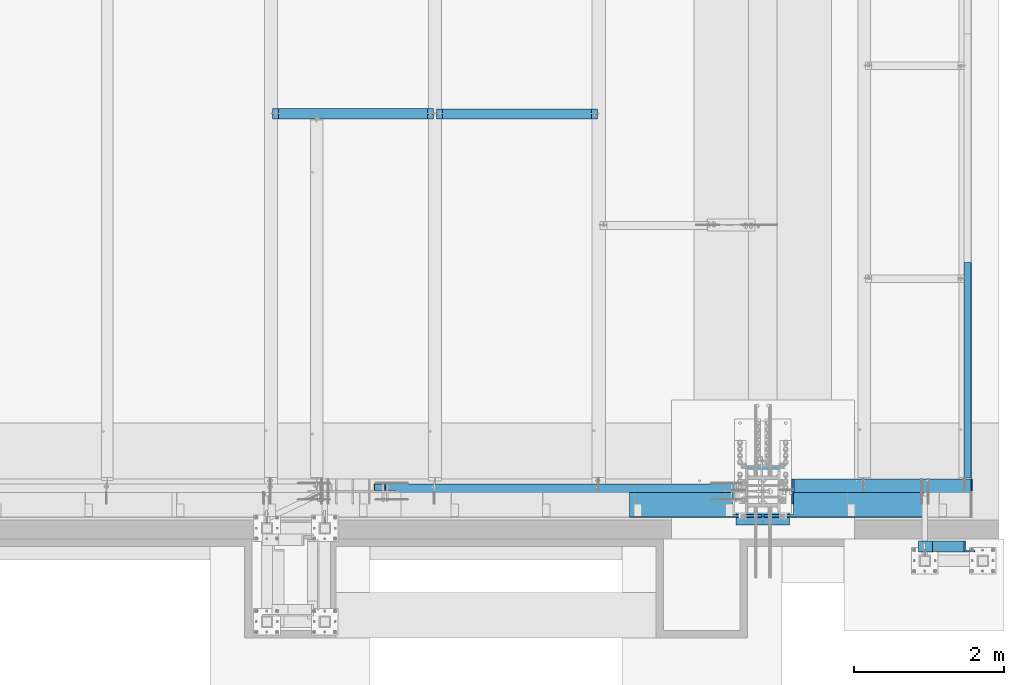
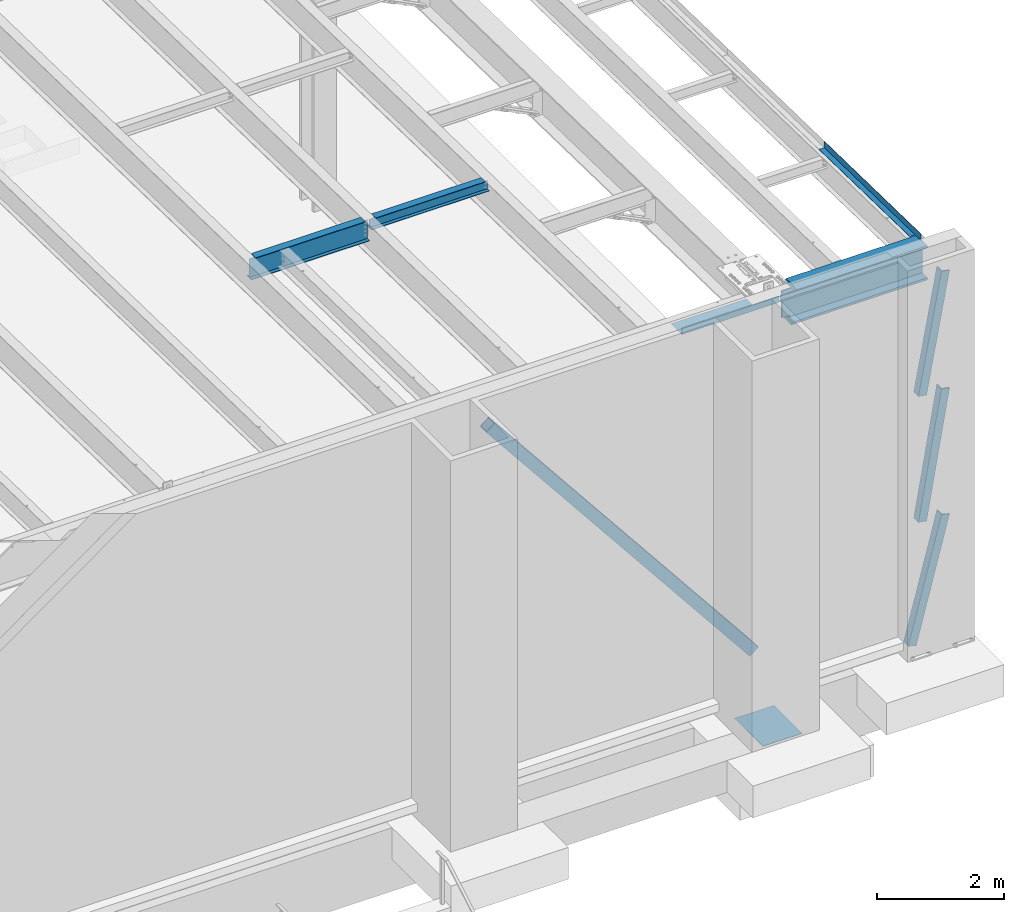
# One storey, part 1111 of 1763: 7 beams, 4 members, 8 elements without a shape of their own.
"""IFC2X3 building model written with IfcOpenShell, lengths in millimetres."""

from ifc_helpers import new_model, si_unit, frame, origin_with_axes, place, context, subcontext, project, spatial, faceted_brep, material, type_object, element, aggregate, save


model = new_model("IFC2X3")

# Units and contexts
model_context = context("Model", 3, precision=1e-05, world=origin_with_axes())
body_context = subcontext(model_context, "Body", "Model", "MODEL_VIEW")
ifc_project = project(units=[si_unit("LENGTHUNIT", "METRE", prefix="MILLI"), si_unit("AREAUNIT", "SQUARE_METRE"), si_unit("VOLUMEUNIT", "CUBIC_METRE"), si_unit("MASSUNIT", "GRAM", prefix="KILO"), si_unit("TIMEUNIT", "SECOND"), si_unit("PLANEANGLEUNIT", "RADIAN"), si_unit("SOLIDANGLEUNIT", "STERADIAN"), si_unit("THERMODYNAMICTEMPERATUREUNIT", "DEGREE_CELSIUS"), si_unit("LUMINOUSINTENSITYUNIT", "LUMEN")], contexts=[model_context])

# Site, building, storey
site_placement = place(None, origin_with_axes())
site = spatial("IfcSite", under=ifc_project, at=site_placement, CompositionType="ELEMENT")
building_placement = place(site_placement, origin_with_axes())
building = spatial("IfcBuilding", under=site, at=building_placement, Name="Undefined", CompositionType="ELEMENT")
storey_placement = place(building_placement, origin_with_axes())
storey = spatial("IfcBuildingStorey", under=building, at=storey_placement, Name="Undefined", CompositionType="ELEMENT", Elevation=0.0)

# Assembly, beam
assembly_1_placement = place(storey_placement, origin_with_axes())
assembly_1 = element("IfcElementAssembly", 1, at=assembly_1_placement, inside=storey, Name="BEAM", AssemblyPlace="NOTDEFINED", PredefinedType="RIGID_FRAME")
ifc_material_1 = material(Name="STEEL/A992")
beam_type_1 = type_object("IfcBeamType", Name="W8X18", PredefinedType="NOTDEFINED")
beam_1_placement = place(assembly_1_placement, frame((-28396.6372736983, -8686.8, 11996.3724330607), z_axis=(0.0, 0.0, 1.0), x_axis=(1.0, 0.0, 0.0)))
beam_1 = element("IfcBeam", 2, at=beam_1_placement, type_object=beam_type_1, material=ifc_material_1, Name="BEAM", ObjectType="W8X18", context=body_context, shape_type="Brep", body=[
    faceted_brep([(2084.38749999999, -66.6749999999993, 103.1875), (2084.38749999999, -66.6749999999993, 95.25), (2084.38749999999, -3.17499999999927, 95.25), (2084.38749999999, -3.17499999999927, 77.5275014878825), (2084.38749999999, 3.17499999999927, 77.5275014878825), (2084.38749999999, 3.17499999999927, 95.25), (2084.38749999999, 66.6749999999993, 95.25), (2084.38749999999, 66.6749999999993, 103.1875), (2085.35422992258, -3.17499999999927, 72.6674219698361), (2085.35422992258, 3.17499999999927, 72.6674219698361), (2088.10724382306, -3.17500000000018, 68.5472454972532), (2088.10724382306, 3.17500000000018, 68.5472454972532), (2092.22742029121, -3.17500000000018, 65.7942315967757), (2092.22742029121, 3.17500000000018, 65.7942315967757), (2097.08749980926, -3.17500000000018, 64.8275016741882), (2097.08749980926, 3.17500000000018, 64.8275016741882), (2166.93749999999, -3.17500000000018, 64.8275016741882), (2166.93749999999, 3.17500000000018, 64.8275016741882), (100.012500000001, -66.6749999999993, 103.1875), (100.012500000001, 66.6749999999993, 103.1875), (100.012500000001, 66.6749999999993, 95.25), (100.012500000001, 3.17499999999927, 95.25), (100.012500000001, 3.17499999999927, 77.5275014878825), (100.012500000001, -3.17499999999927, 77.5275014878825), (100.012500000001, -3.17499999999927, 95.25), (100.012500000001, -66.6749999999993, 95.25), (99.0457700774132, 3.17499999999927, 72.6674219698361), (99.0457700774132, -3.17499999999927, 72.6674219698361), (96.2927561769247, 3.17500000000018, 68.5472454911378), (96.2927561769247, -3.17500000000018, 68.5472454911378), (92.1725797087711, 3.17500000000018, 65.7942315906603), (92.1725797087711, -3.17500000000018, 65.7942315906603), (87.3125001907247, 3.17500000000018, 64.8275016680727), (87.3125001907247, -3.17500000000018, 64.8275016680727), (17.4624999999905, 3.17500000000018, 64.8275016680727), (17.4624999999905, -3.17500000000018, 64.8275016680727), (17.4624999999905, 3.17500000000018, -95.25), (17.4624999999905, 66.6750000000002, -95.25), (17.4624999999905, 66.6750000000002, -103.1875), (17.4624999999905, -66.6750000000002, -103.1875), (17.4624999999905, -66.6750000000002, -95.25), (17.4624999999905, -3.17500000000018, -95.25), (2166.93749999999, 3.17500000000018, -95.25), (2166.93749999999, 66.6750000000002, -95.25), (2166.93749999999, 66.6750000000002, -103.1875), (2166.93749999999, -66.6750000000002, -103.1875), (2166.93749999999, -66.6750000000002, -95.25), (2166.93749999999, -3.17500000000018, -95.25)], [[[0, 1, 2, 3, 4, 5, 6, 7]], [[8, 9, 4, 3]], [[10, 11, 9, 8]], [[12, 13, 11, 10]], [[14, 15, 13, 12]], [[16, 17, 15, 14]], [[18, 19, 20, 21, 22, 23, 24, 25]], [[23, 22, 26, 27]], [[27, 26, 28, 29]], [[29, 28, 30, 31]], [[31, 30, 32, 33]], [[33, 32, 34, 35]], [[36, 37, 38, 39, 40, 41, 35, 34]], [[37, 36, 42, 43]], [[38, 37, 43, 44]], [[39, 38, 44, 45]], [[40, 39, 45, 46]], [[41, 40, 46, 47]], [[12, 10, 8, 3, 2, 24, 23, 27, 29, 31, 33, 35, 41, 47, 16, 14]], [[25, 24, 2, 1]], [[18, 25, 1, 0]], [[19, 18, 0, 7]], [[20, 19, 7, 6]], [[21, 20, 6, 5]], [[42, 36, 34, 32, 30, 28, 26, 22, 21, 5, 4, 9, 11, 13, 15, 17]], [[47, 46, 45, 44, 43, 42, 17, 16]]]),
])
aggregate(assembly_1, [beam_1])

# Assembly, members
assembly_2_placement = place(storey_placement, origin_with_axes())
assembly_2 = element("IfcElementAssembly", 3, at=assembly_2_placement, inside=storey, Name="FRAME", AssemblyPlace="NOTDEFINED", PredefinedType="RIGID_FRAME")
ifc_material_2 = material(Name="STEEL/A36")
member_type_1 = type_object("IfcMemberType", Name="L6X6X7/8", PredefinedType="NOTDEFINED")
member_1_placement = place(assembly_2_placement, frame((-21894.238056465, -14450.1432982799, 5067.3), z_axis=(0.967568844116864, 0.0, -0.252607466030511), x_axis=(0.252607466030511, 0.0, 0.967568844116864)))
member_1 = element("IfcMember", 4, at=member_1_placement, type_object=member_type_1, material=ifc_material_2, Name="V. BRACE", ObjectType="L6X6X7/8", context=body_context, shape_type="Brep", body=[
    faceted_brep([(60.0245163736663, 76.2000000000007, -76.1999999999643), (59.3416290607647, 76.2000000000007, 76.2000000000189), (2461.06518876234, 76.2000000000007, 76.2000000010594), (2461.0651887624, 76.2000000000007, -76.1999999989166), (59.3416290607647, 53.9750000000004, 76.2000000000189), (2461.06518876234, 53.9750000000004, 76.2000000010594), (59.9249286405347, 53.9750000000004, -53.9749999999658), (2461.06518876239, 53.9750000000004, -53.9749999989217), (59.9249286405347, -76.2000000000007, -53.9749999999658), (2461.06518876239, -76.2000000000007, -53.9749999989217), (60.0245163736663, -76.2000000000007, -76.1999999999643), (2461.0651887624, -76.2000000000007, -76.1999999989166)], [[[0, 1, 2, 3]], [[1, 4, 5, 2]], [[4, 6, 7, 5]], [[6, 8, 9, 7]], [[8, 10, 11, 9]], [[10, 0, 3, 11]], [[5, 7, 9, 11, 3, 2]], [[10, 8, 6, 4, 1, 0]]]),
])
member_2_placement = place(assembly_2_placement, frame((-21692.7923567803, -14450.1432982799, 9867.9), z_axis=(0.983225526923755, 0.0, -0.182393977985856), x_axis=(0.182393977985856, 0.0, 0.983225526923755)))
member_2 = element("IfcMember", 5, at=member_2_placement, type_object=member_type_1, material=ifc_material_2, Name="V. BRACE", ObjectType="L6X6X7/8", context=body_context, shape_type="Brep", body=[
    faceted_brep([(9.09494701772928e-13, 76.2000000000007, -76.2000000000844), (0.0, 76.2000000000007, 76.2000000000771), (2299.16732010794, 76.2000000000007, 76.2000000008775), (2299.16732010795, 76.2000000000007, -76.199999999284), (0.0, 53.9750000000004, 76.2000000000771), (2299.16732010794, 53.9750000000004, 76.2000000008775), (1.81898940354586e-12, 53.9750000000004, -53.9750000000604), (2299.16732010795, 53.9750000000004, -53.97499999926), (1.81898940354586e-12, -76.2000000000007, -53.9750000000604), (2299.16732010795, -76.2000000000007, -53.97499999926), (9.09494701772928e-13, -76.2000000000007, -76.2000000000844), (2299.16732010795, -76.2000000000007, -76.199999999284)], [[[0, 1, 2, 3]], [[1, 4, 5, 2]], [[4, 6, 7, 5]], [[6, 8, 9, 7]], [[8, 10, 11, 9]], [[10, 0, 3, 11]], [[5, 7, 9, 11, 3, 2]], [[10, 8, 6, 4, 1, 0]]]),
])
member_3_placement = place(assembly_2_placement, frame((-21692.5763856551, -14450.1432982799, 7448.55), z_axis=(0.985337026870794, 0.0, -0.170619293977627), x_axis=(0.170619293977628, 0.0, 0.985337026870794)))
member_3 = element("IfcMember", 6, at=member_3_placement, type_object=member_type_1, material=ifc_material_2, Name="V. BRACE", ObjectType="L6X6X7/8", context=body_context, shape_type="Brep", body=[
    faceted_brep([(9.09494701772928e-13, 76.2000000000007, -76.2000000000844), (0.0, 76.2000000000007, 76.2000000000771), (2455.35277151341, 76.2000000000007, 76.2000000014268), (2455.35277151334, 76.2000000000007, -76.199999998742), (0.0, 53.9750000000004, 76.2000000000771), (2455.35277151341, 53.9750000000004, 76.2000000014268), (1.81898940354586e-12, 53.9750000000004, -53.9750000000604), (2455.35277151335, 53.9750000000004, -53.974999998718), (1.81898940354586e-12, -76.2000000000007, -53.9750000000604), (2455.35277151335, -76.2000000000007, -53.974999998718), (9.09494701772928e-13, -76.2000000000007, -76.2000000000844), (2455.35277151334, -76.2000000000007, -76.199999998742)], [[[0, 1, 2, 3]], [[1, 4, 5, 2]], [[4, 6, 7, 5]], [[6, 8, 9, 7]], [[8, 10, 11, 9]], [[10, 0, 3, 11]], [[5, 7, 9, 11, 3, 2]], [[10, 8, 6, 4, 1, 0]]]),
])
aggregate(assembly_2, [member_1, member_2, member_3])

# Assembly, beam
assembly_3_placement = place(storey_placement, origin_with_axes())
assembly_3 = element("IfcElementAssembly", 7, at=assembly_3_placement, inside=storey, Name="BEAM", AssemblyPlace="NOTDEFINED", PredefinedType="RIGID_FRAME")
beam_type_2 = type_object("IfcBeamType", PredefinedType="NOTDEFINED")
beam_2_placement = place(assembly_3_placement, frame((-21348.1372736984, -12191.7219162731, 12176.0092546754), z_axis=(0.0, -0.999781542838788, 0.0209013539966307), x_axis=(1.0, 0.0, 0.0)))
beam_2 = element("IfcBeam", 8, at=beam_2_placement, type_object=beam_type_2, material=ifc_material_2, Name="BENT_PLATE", context=body_context, shape_type="Brep", body=[
    faceted_brep([(101.59999847411, -3.17499999956453, 1342.05830135889), (101.59999847411, 3.17500019330328, 1342.05830135255), (95.2499984741116, 3.17500000044129, 1342.05830135255), (0.0, 3.17500000044492, 1342.05830135255), (0.0, -3.17499999955908, 1342.05830135889), (101.599999809252, 3.17499999999927, 1524.0), (95.2499984741262, 3.17499999910251, 1523.99999999978), (101.599998474125, -3.17499999909887, -1523.99999999978), (0.0, -3.17499999999927, -1523.99999999999), (0.0, 3.17499999999927, -1523.99999999999), (95.2499984741262, 3.17500000090149, -1523.99999999977), (95.2499984741262, 123.825003589236, -1523.9999999997), (101.599998474125, 123.825003589236, -1523.9999999997), (101.599998474125, 123.825003587437, 1523.99999999985), (95.2499984741262, 123.825003587437, 1523.99999999985)], [[[0, 1, 2, 3, 4]], [[5, 6, 2, 1]], [[7, 8, 9, 10, 11, 12]], [[13, 12, 11, 14]], [[0, 7, 12, 13, 5, 1]], [[8, 7, 0, 4]], [[9, 8, 4, 3]], [[10, 9, 3, 2]], [[14, 11, 10, 2, 6]], [[13, 14, 6, 5]]]),
])
aggregate(assembly_3, [beam_2])

assembly_4_placement = place(storey_placement, origin_with_axes())
assembly_4 = element("IfcElementAssembly", 9, at=assembly_4_placement, inside=storey, Name="BEAM", AssemblyPlace="NOTDEFINED", PredefinedType="RIGID_FRAME")
beam_type_3 = type_object("IfcBeamType", Name="W16X26", PredefinedType="NOTDEFINED")
beam_3_placement = place(assembly_4_placement, frame((-30581.0372736983, -8686.8, 11899.5349330607), z_axis=(0.0, 0.0, 1.0), x_axis=(1.0, 0.0, 0.0)))
beam_3 = element("IfcBeam", 10, at=beam_3_placement, type_object=beam_type_3, material=ifc_material_1, Name="BEAM", ObjectType="W16X26", context=body_context, shape_type="Brep", body=[
    faceted_brep([(2084.38749999999, -69.8500000000004, 200.025), (2084.38749999999, -69.8500000000004, 190.5), (2084.38749999999, -3.17499999999927, 190.5), (2084.38749999999, -3.17499999999927, 180.715001487652), (2084.38749999999, 3.17499999999927, 180.715001487652), (2084.38749999999, 3.17499999999927, 190.5), (2084.38749999999, 69.8500000000004, 190.5), (2084.38749999999, 69.8500000000004, 200.025), (2085.35422992258, -3.17499999999927, 175.854921969605), (2085.35422992258, 3.17499999999927, 175.854921969605), (2088.10724382306, -3.17499999999927, 171.734745501451), (2088.10724382306, 3.17499999999927, 171.734745501451), (2092.22742029121, -3.17499999999927, 168.981731600974), (2092.22742029121, 3.17499999999927, 168.981731600974), (2097.08749980926, -3.17499999999927, 168.015001678386), (2097.08749980926, 3.17499999999927, 168.015001678386), (2166.93749999999, -3.17499999999927, 168.015001678386), (2166.93749999999, 3.17499999999927, 168.015001678386), (100.012500000012, -69.8500000000004, 200.025), (100.012500000012, 69.8500000000004, 200.025), (100.012500000012, 69.8500000000004, 190.5), (100.012500000012, 3.17499999999927, 190.5), (100.012500000012, 3.17499999999927, 180.715001488035), (100.012500000012, -3.17499999999927, 180.715001488035), (100.012500000012, -3.17499999999927, 190.5), (100.012500000012, -69.8500000000004, 190.5), (99.0457700774205, 3.17499999999927, 175.854921969989), (99.0457700774205, -3.17499999999927, 175.854921969989), (96.2927561769466, 3.17499999999927, 171.734745501835), (96.2927561769466, -3.17499999999927, 171.734745501835), (92.1725797087929, 3.17499999999927, 168.981731601358), (92.1725797087929, -3.17499999999927, 168.981731601358), (87.3125001907465, 3.17499999999927, 168.01500167877), (87.3125001907465, -3.17499999999927, 168.01500167877), (17.4625000000087, 3.17499999999927, 168.01500167877), (17.4625000000087, -3.17499999999927, 168.01500167877), (17.4625000000087, 3.17499999999927, -190.5), (17.4625000000087, 69.8500000000004, -190.5), (17.4625000000087, 69.8500000000004, -200.025), (17.4625000000087, -69.8500000000004, -200.025), (17.4625000000087, -69.8500000000004, -190.5), (17.4625000000087, -3.17499999999927, -190.5), (2166.93749999999, 3.17499999999927, -190.5), (2166.93749999999, 69.8500000000004, -190.5), (2166.93749999999, 69.8500000000004, -200.025), (2166.93749999999, -69.8500000000004, -200.025), (2166.93749999999, -69.8500000000004, -190.5), (2166.93749999999, -3.17499999999927, -190.5)], [[[0, 1, 2, 3, 4, 5, 6, 7]], [[8, 9, 4, 3]], [[10, 11, 9, 8]], [[12, 13, 11, 10]], [[14, 15, 13, 12]], [[16, 17, 15, 14]], [[18, 19, 20, 21, 22, 23, 24, 25]], [[23, 22, 26, 27]], [[27, 26, 28, 29]], [[29, 28, 30, 31]], [[31, 30, 32, 33]], [[33, 32, 34, 35]], [[36, 37, 38, 39, 40, 41, 35, 34]], [[37, 36, 42, 43]], [[38, 37, 43, 44]], [[39, 38, 44, 45]], [[40, 39, 45, 46]], [[41, 40, 46, 47]], [[12, 10, 8, 3, 2, 24, 23, 27, 29, 31, 33, 35, 41, 47, 16, 14]], [[25, 24, 2, 1]], [[18, 25, 1, 0]], [[19, 18, 0, 7]], [[20, 19, 7, 6]], [[21, 20, 6, 5]], [[42, 36, 34, 32, 30, 28, 26, 22, 21, 5, 4, 9, 11, 13, 15, 17]], [[47, 46, 45, 44, 43, 42, 17, 16]]]),
])
aggregate(assembly_4, [beam_3])

assembly_5_placement = place(storey_placement, origin_with_axes())
assembly_5 = element("IfcElementAssembly", 11, at=assembly_5_placement, inside=storey, Name="BEAM", AssemblyPlace="NOTDEFINED", PredefinedType="RIGID_FRAME")
beam_type_4 = type_object("IfcBeamType", PredefinedType="NOTDEFINED")
beam_4_placement = place(assembly_5_placement, frame((-22948.3372730615, -13728.6998186171, 12207.875), z_axis=(-1.0, 0.0, 0.0), x_axis=(0.0, -1.0, 0.0)))
beam_4 = element("IfcBeam", 12, at=beam_4_placement, type_object=beam_type_4, material=ifc_material_2, Name="BENT_PLATE", context=body_context, shape_type="Brep", body=[
    faceted_brep([(292.099990341079, -3.17499999999927, 673.100030919406), (292.099990341079, 3.17499999999927, 673.100030919406), (0.0, 3.17500000000291, 673.099987030029), (0.0, -3.17500000000291, 673.099987030029), (292.099987518222, -3.17499999999927, 1066.8), (292.099987518222, 3.17499999999927, 1066.8), (336.549987792969, -3.17499999999927, -1066.8), (0.0, -3.17499999999927, -1066.8), (0.0, 3.17499999999927, -1066.8), (330.19998779297, 3.17499999999927, -1066.8), (330.19998779297, 123.825000000001, -1066.8), (336.549987792969, 123.825000000001, -1066.8), (330.19998779297, 3.17499999999927, 1066.8), (330.19998779297, 123.825000000001, 1066.8), (336.549987792969, 123.825000000001, 1066.8), (336.549987792969, -3.17499999999927, 1066.8)], [[[0, 1, 2, 3]], [[4, 5, 1, 0]], [[6, 7, 8, 9, 10, 11]], [[9, 12, 13, 10]], [[14, 11, 10, 13]], [[15, 6, 11, 14]], [[3, 7, 6, 15, 4, 0]], [[8, 7, 3, 2]], [[12, 9, 8, 2, 1, 5]], [[15, 14, 13, 12, 5, 4]]]),
])

assembly_6_placement = place(storey_placement, origin_with_axes())
assembly_6 = element("IfcElementAssembly", 13, at=assembly_6_placement, inside=storey, Name="BEAM", AssemblyPlace="NOTDEFINED", PredefinedType="RIGID_FRAME")
beam_5_placement = place(assembly_6_placement, frame((-24921.5997736984, -13728.6998186171, 12207.875), z_axis=(-1.0, 0.0, 0.0), x_axis=(0.0, -1.0, 0.0)))
beam_5 = element("IfcBeam", 14, at=beam_5_placement, type_object=beam_type_4, material=ifc_material_2, Name="BENT_PLATE", context=body_context, shape_type="Brep", body=[
    faceted_brep([(292.099992404377, -3.17499999999927, -487.362530517577), (292.099992404377, 3.17499999999927, -487.362530517577), (292.099987829859, 3.17499999999927, -881.0625), (292.099987829859, -3.17499999999927, -881.0625), (0.0, -3.17499999999927, -487.362530517577), (0.0, 3.17499999999927, -487.362530517577), (330.19998779297, 3.17499999999927, 881.0625), (0.0, 3.17499999999927, 881.0625), (0.0, -3.17499999999927, 881.0625), (336.549987792969, -3.17499999999927, 881.0625), (336.549987792969, 123.825000000001, 881.0625), (330.19998779297, 123.825000000001, 881.0625), (330.19998779297, 3.17499999999927, -881.0625), (330.19998779297, 123.825000000001, -881.0625), (336.549987792969, 123.825000000001, -881.0625), (336.549987792969, -3.17499999999927, -881.0625)], [[[0, 1, 2, 3]], [[4, 5, 1, 0]], [[6, 7, 8, 9, 10, 11]], [[12, 6, 11, 13]], [[10, 14, 13, 11]], [[9, 15, 14, 10]], [[12, 13, 14, 15, 3, 2]], [[7, 6, 12, 2, 1, 5]], [[8, 7, 5, 4]], [[15, 9, 8, 4, 0, 3]]]),
])
aggregate(assembly_6, [beam_5])

assembly_7_placement = place(storey_placement, origin_with_axes())
assembly_7 = element("IfcElementAssembly", 15, at=assembly_7_placement, inside=storey, Name="TEMPLATE", AssemblyPlace="NOTDEFINED", PredefinedType="RIGID_FRAME")
beam_type_5 = type_object("IfcBeamType", PredefinedType="NOTDEFINED")
beam_6_placement = place(assembly_7_placement, frame((-24027.8372736984, -14160.5000000001, 3851.275), z_axis=(-1.0, 0.0, 0.0), x_axis=(0.0, 1.0, 0.0)))
beam_6 = element("IfcBeam", 16, at=beam_6_placement, type_object=beam_type_5, material=ifc_material_2, Name="TEMPLATE", context=body_context, shape_type="Brep", body=[
    faceted_brep([(0.0, 3.17500000000018, -355.599999999999), (0.0, 3.17500000000018, 355.599999999999), (889.0, 3.17500000000018, 355.599999999999), (889.0, 3.17500000000018, -355.599999999999), (0.0, -3.17500000000018, 355.599999999999), (889.0, -3.17500000000018, 355.599999999999), (0.0, -3.17500000000018, -355.599999999999), (889.0, -3.17500000000018, -355.599999999999)], [[[0, 1, 2, 3]], [[1, 4, 5, 2]], [[4, 6, 7, 5]], [[6, 0, 3, 7]], [[5, 7, 3, 2]], [[6, 4, 1, 0]]]),
])
aggregate(assembly_7, [beam_6])

# Assembly, member
assembly_8_placement = place(storey_placement, origin_with_axes())
assembly_8 = element("IfcElementAssembly", 17, at=assembly_8_placement, inside=storey, Name="V. BRACE", AssemblyPlace="NOTDEFINED", PredefinedType="RIGID_FRAME")
ifc_material_3 = material()
member_type_2 = type_object("IfcMemberType", Name="HSS8X8X1/2", PredefinedType="NOTDEFINED")
member_4_placement = place(assembly_8_placement, frame((-24027.8372736984, -13716.0, 5054.6), z_axis=(0.780585099299328, 0.0, 0.625049520239683), x_axis=(-0.625049520239685, 0.0, 0.780585099299327)))
member_4 = element("IfcMember", 18, at=member_4_placement, type_object=member_type_2, material=ifc_material_3, Name="V. BRACE", ObjectType="HSS8X8X1/2", context=body_context, shape_type="Brep", body=[
    faceted_brep([(8167.45666198509, -11.1124999999993, -88.9000000051365), (8167.4566619851, -11.1124999999993, -101.600000005134), (7938.85666191444, -11.1124999999993, -101.600000004992), (7938.85666191444, -11.1124999999993, -88.9000000049891), (7935.21160236714, -10.3874525762076, -101.600000004984), (7935.21160236714, -10.3874525762076, -88.9000000049891), (7932.12147009337, -8.32269220253147, -101.600000004984), (7932.12147009337, -8.32269220253147, -88.9000000049873), (7930.05670971969, -5.23255992876511, -101.600000004981), (7930.05670971969, -5.23255992876511, -88.9000000049873), (7929.3316622959, -1.587500381469, -101.600000004984), (7929.3316622959, -1.587500381469, -88.9000000049837), (7929.3316622959, 1.58750076294018, -101.600000004984), (7929.3316622959, 1.58750076294018, -88.9000000049837), (7930.05670971969, 5.23256031023629, -101.600000004981), (7930.05670971969, 5.23256031023629, -88.9000000049873), (7932.12147009337, 8.32269258400265, -101.600000004984), (7932.12147009337, 8.32269258400265, -88.9000000049873), (7935.21160236714, 10.3874529576788, -101.600000004984), (7935.21160236714, 10.3874529576788, -88.9000000049891), (7938.85666191444, 11.1125003814705, -101.600000004992), (7938.85666191444, 11.1125003814705, -88.9000000049891), (8167.45666198509, 11.1125003814705, -88.9000000051365), (8167.4566619851, 11.1125003814705, -101.600000005134), (735.738587907468, -8.79998026753674, -88.9000000004289), (735.735256781103, -8.79998034885284, -101.60000000043), (732.090197108417, -9.52502777265181, -101.600000000422), (732.093528234782, -9.52502769133571, -88.9000000004307), (738.828720287536, -6.73521989385517, -88.9000000004344), (738.825389161171, -6.73521997517128, -101.60000000043), (740.893480732244, -3.64508762008518, -88.9000000004362), (740.890149605875, -3.64508770140128, -101.600000000428), (741.618528180978, -2.80727890640264e-05, -88.9000000004362), (741.615197054616, -2.81541051663226e-05, -101.600000000431), (740.893480732251, 3.6450543625142, -88.9000000004362), (740.890149605882, 3.6450542811981, -101.60000000043), (738.828720287547, 6.73518663627692, -88.9000000004326), (738.825389161182, 6.73518655496082, -101.600000000428), (735.738587907479, 8.79994700994757, -88.9000000004326), (735.735256781114, 8.79994692863147, -101.600000000426), (732.093528234793, 9.52499443373381, -88.9000000004289), (732.090197108428, 9.52499435241771, -101.600000000424), (505.133093628454, 9.52499443335364, -88.9000000002834), (505.133093628465, 9.52499435203754, -101.600000000284), (8167.45666198509, 88.8999999999996, -88.9000000051365), (8167.45666198497, 88.8999999999996, 88.8999999947901), (505.133093628327, 88.8999999999996, 88.8999999996413), (505.133093628454, 88.8999999999996, -88.9000000002834), (735.78855480297, -8.7999790477952, 101.599999999491), (735.785223676601, -8.79997912911131, 88.8999999994958), (732.140164003918, -9.52502655291028, 88.8999999994976), (732.143495130284, -9.52502647159417, 101.599999999493), (738.878687183038, -6.73521867411364, 101.599999999491), (738.875356056673, -6.73521875542974, 88.899999999494), (740.943447627746, -3.64508640034364, 101.599999999487), (740.940116501377, -3.64508648165975, 88.8999999994921), (741.668495076479, -2.68530475295847e-05, 101.599999999487), (741.665163950114, -2.69343636318808e-05, 88.899999999494), (740.943447627753, 3.64505558225574, 101.599999999487), (740.940116501384, 3.64505550093963, 88.8999999994921), (738.878687183049, 6.73518785601846, 101.599999999487), (738.875356056684, 6.73518777470235, 88.8999999994921), (735.788554802981, 8.79994822968911, 101.599999999493), (735.785223676616, 8.79994814837301, 88.8999999994976), (732.143495130294, 9.52499565347534, 101.599999999491), (732.140164003926, 9.52499557215924, 88.8999999994994), (505.133093628319, 9.52499565309517, 101.599999999638), (505.133093628327, 9.52499557177907, 88.8999999996413), (505.133093628465, 101.6, -101.600000000284), (505.133093628319, 101.6, 101.599999999638), (8167.45666198496, 101.6, 101.599999994787), (8167.4566619851, 101.6, -101.600000005134), (8167.45666198496, 11.1125003814705, 101.599999994787), (8167.45666198497, 11.1125003814705, 88.8999999947901), (7938.85666191443, 11.1125003814705, 101.599999994929), (7938.85666191443, 11.1125003814705, 88.8999999949356), (7935.21160236713, 10.3874529576788, 101.599999994933), (7935.21160236713, 10.3874529576788, 88.8999999949356), (7932.12147009336, 8.32269258400265, 101.599999994936), (7932.12147009336, 8.32269258400265, 88.8999999949392), (7930.05670971968, 5.23256031023629, 101.599999994936), (7930.05670971968, 5.23256031023629, 88.8999999949392), (7929.33166229589, 1.58750076294018, 101.599999994938), (7929.33166229589, 1.58750076294018, 88.899999994941), (7929.33166229589, -1.587500381469, 101.599999994938), (7929.33166229589, -1.587500381469, 88.899999994941), (7930.05670971968, -5.23255992876511, 101.599999994936), (7930.05670971968, -5.23255992876511, 88.8999999949392), (7932.12147009336, -8.32269220253147, 101.599999994936), (7932.12147009336, -8.32269220253147, 88.8999999949392), (7935.21160236713, -10.3874525762076, 101.599999994933), (7935.21160236713, -10.3874525762076, 88.8999999949356), (7938.85666191443, -11.1124999999993, 101.599999994929), (7938.85666191443, -11.1124999999993, 88.8999999949356), (8167.45666198496, -11.1124999999993, 101.599999994787), (8167.45666198497, -11.1124999999993, 88.8999999947901), (8167.45666198496, -101.6, 101.599999994787), (8167.4566619851, -101.6, -101.600000005134), (8167.45666198509, -88.8999999999996, -88.9000000051365), (8167.45666198497, -88.8999999999996, 88.8999999947901), (505.133093628319, -101.6, 101.599999999638), (505.133093628465, -101.6, -101.600000000284), (505.133093628465, -9.52502777317932, -101.600000000284), (505.133093628454, -9.52502769186322, -88.9000000002834), (505.133093628454, -88.8999999999996, -88.9000000002834), (505.133093628327, -88.8999999999996, 88.8999999996413), (505.133093628327, -9.52502655343778, 88.8999999996413), (505.133093628319, -9.52502647212168, 101.599999999638)], [[[0, 1, 2, 3]], [[3, 2, 4, 5]], [[5, 4, 6, 7]], [[7, 6, 8, 9]], [[9, 8, 10, 11]], [[11, 10, 12, 13]], [[13, 12, 14, 15]], [[15, 14, 16, 17]], [[17, 16, 18, 19]], [[19, 18, 20, 21]], [[22, 21, 20, 23]], [[24, 25, 26, 27]], [[28, 29, 25, 24]], [[30, 31, 29, 28]], [[32, 33, 31, 30]], [[34, 35, 33, 32]], [[36, 37, 35, 34]], [[38, 39, 37, 36]], [[40, 41, 39, 38]], [[41, 40, 42, 43]], [[44, 45, 46, 47]], [[48, 49, 50, 51]], [[52, 53, 49, 48]], [[54, 55, 53, 52]], [[56, 57, 55, 54]], [[58, 59, 57, 56]], [[60, 61, 59, 58]], [[62, 63, 61, 60]], [[64, 65, 63, 62]], [[65, 64, 66, 67]], [[68, 43, 42, 47, 46, 67, 66, 69]], [[70, 71, 68, 69]], [[45, 44, 22, 23, 71, 70, 72, 73]], [[72, 74, 75, 73]], [[76, 77, 75, 74]], [[78, 79, 77, 76]], [[80, 81, 79, 78]], [[82, 83, 81, 80]], [[84, 85, 83, 82]], [[86, 87, 85, 84]], [[88, 89, 87, 86]], [[90, 91, 89, 88]], [[92, 93, 91, 90]], [[94, 95, 93, 92]], [[96, 97, 1, 0, 98, 99, 95, 94]], [[97, 96, 100, 101]], [[26, 25, 29, 31, 33, 35, 37, 39, 41, 43, 68, 71, 23, 20, 18, 16, 14, 12, 10, 8, 6, 4, 2, 1, 97, 101, 102]], [[27, 26, 102, 103]], [[98, 0, 3, 5, 7, 9, 11, 13, 15, 17, 19, 21, 22, 44, 47, 42, 40, 38, 36, 34, 32, 30, 28, 24, 27, 103, 104]], [[99, 98, 104, 105]], [[50, 49, 53, 55, 57, 59, 61, 63, 65, 67, 46, 45, 73, 75, 77, 79, 81, 83, 85, 87, 89, 91, 93, 95, 99, 105, 106]], [[51, 50, 106, 107]], [[96, 94, 92, 90, 88, 86, 84, 82, 80, 78, 76, 74, 72, 70, 69, 66, 64, 62, 60, 58, 56, 54, 52, 48, 51, 107, 100]], [[106, 105, 104, 103, 102, 101, 100, 107]]]),
])
aggregate(assembly_8, [member_4])

# Beam
beam_type_6 = type_object("IfcBeamType", Name="W24X229", PredefinedType="NOTDEFINED")
beam_7_placement = place(assembly_5_placement, frame((-24027.8372736983, -13715.9998186171, 11874.5), z_axis=(0.0, 0.0, 1.0), x_axis=(1.0, 0.0, 0.0)))
beam_7 = element("IfcBeam", 19, at=beam_7_placement, type_object=beam_type_6, material=ifc_material_1, Name="BEAM", ObjectType="W24X229", context=body_context, shape_type="Brep", body=[
    faceted_brep([(416.188575111595, -166.6875, 330.200000000001), (416.188575111595, 166.6875, 330.200000000001), (390.525006052743, 166.6875, 285.75), (390.525006052743, 11.90625, 285.75), (390.295794582798, 11.90625, 285.352999496459), (390.295794582798, -11.90625, 285.352999496459), (390.525006052743, -11.90625, 285.75), (390.525006052743, -166.6875, 285.75), (417.512995021581, -11.90625, 285.352999496459), (417.512995021581, 11.90625, 285.352999496459), (437.264153892043, 11.90625, 275.165223559896), (437.264153892043, -11.90625, 275.165223559896), (440.960203890907, 11.90625, 271.771709030012), (440.960203890907, -11.90625, 271.771709030012), (442.418886510673, 11.90625, 266.970774592486), (442.418886510673, -11.90625, 266.970774592486), (441.235411415102, 11.90625, 262.094699002753), (441.235411415102, -11.90625, 262.094699002753), (437.738197737577, 11.90625, 258.49661299039), (437.738197737577, -11.90625, 258.49661299039), (432.897736441144, 11.90625, 257.174999999999), (432.897736441144, -11.90625, 257.174999999999), (238.125000636814, 11.90625, 257.174999999999), (238.125000636814, -11.90625, 257.174999999999), (238.125004237252, 11.90625, -257.174999999999), (238.125004237252, -11.90625, -257.174999999999), (381.231739901767, 11.90625, -257.174999999999), (381.231739901767, -11.90625, -257.174999999999), (386.07220105817, 11.90625, -258.496612907766), (386.07220105817, -11.90625, -258.496612907766), (389.569414718502, 11.90625, -262.094698718112), (389.569414718502, -11.90625, -262.094698718112), (390.75288998516, 11.90625, -266.970774104922), (390.75288998516, -11.90625, -266.970774104922), (389.294207697814, 11.90625, -271.771708479522), (389.294207697814, -11.90625, -271.771708479522), (385.598158075154, 11.90625, -275.165223187232), (385.598158075154, -11.90625, -275.165223187232), (365.847002619823, 11.90625, -285.352999496459), (365.847002619823, -11.90625, -285.352999496459), (346.56779570135, 11.90625, -285.352999496459), (346.56779570135, -11.90625, -285.352999496459), (2793.99999999998, 11.90625, -285.75), (2793.99999999998, 166.6875, -285.75), (346.338587793351, 166.6875, -285.75), (346.338587793351, 11.90625, -285.75), (2793.99999999998, 166.6875, -330.200000000001), (2793.99999999998, -166.6875, -330.200000000001), (320.675417546292, -166.6875, -330.200000000001), (320.675417546292, 166.6875, -330.200000000001), (2793.99999999998, -166.6875, -285.75), (346.338587793351, -166.6875, -285.75), (2793.99999999998, -11.90625, -285.75), (346.338587793351, -11.90625, -285.75), (2793.99999999998, 11.90625, 285.75), (2793.99999999998, 166.6875, 285.75), (2793.99999999998, 166.6875, 330.200000000001), (2793.99999999998, -166.6875, 330.200000000001), (2793.99999999998, -166.6875, 285.75), (2793.99999999998, -11.90625, 285.75)], [[[0, 1, 2, 3, 4, 5, 6, 7]], [[8, 9, 10, 11]], [[11, 10, 12, 13]], [[13, 12, 14, 15]], [[15, 14, 16, 17]], [[17, 16, 18, 19]], [[19, 18, 20, 21]], [[21, 20, 22, 23]], [[23, 22, 24, 25]], [[26, 27, 25, 24]], [[27, 26, 28, 29]], [[29, 28, 30, 31]], [[31, 30, 32, 33]], [[33, 32, 34, 35]], [[35, 34, 36, 37]], [[37, 36, 38, 39]], [[39, 38, 40, 41]], [[42, 43, 44, 45]], [[46, 47, 48, 49]], [[47, 50, 51, 48]], [[50, 52, 53, 51]], [[41, 40, 45, 44, 49, 48, 51, 53]], [[43, 46, 49, 44]], [[42, 54, 55, 56, 57, 58, 59, 52, 50, 47, 46, 43]], [[58, 57, 0, 7]], [[59, 58, 7, 6]], [[8, 11, 13, 15, 17, 19, 21, 23, 25, 27, 29, 31, 33, 35, 37, 39, 41, 53, 52, 59, 6, 5]], [[9, 8, 5, 4]], [[54, 42, 45, 40, 38, 36, 34, 32, 30, 28, 26, 24, 22, 20, 18, 16, 14, 12, 10, 9, 4, 3]], [[55, 54, 3, 2]], [[56, 55, 2, 1]], [[57, 56, 1, 0]]]),
])

aggregate(assembly_5, [beam_4, beam_7])

save(model, "model.ifc")
